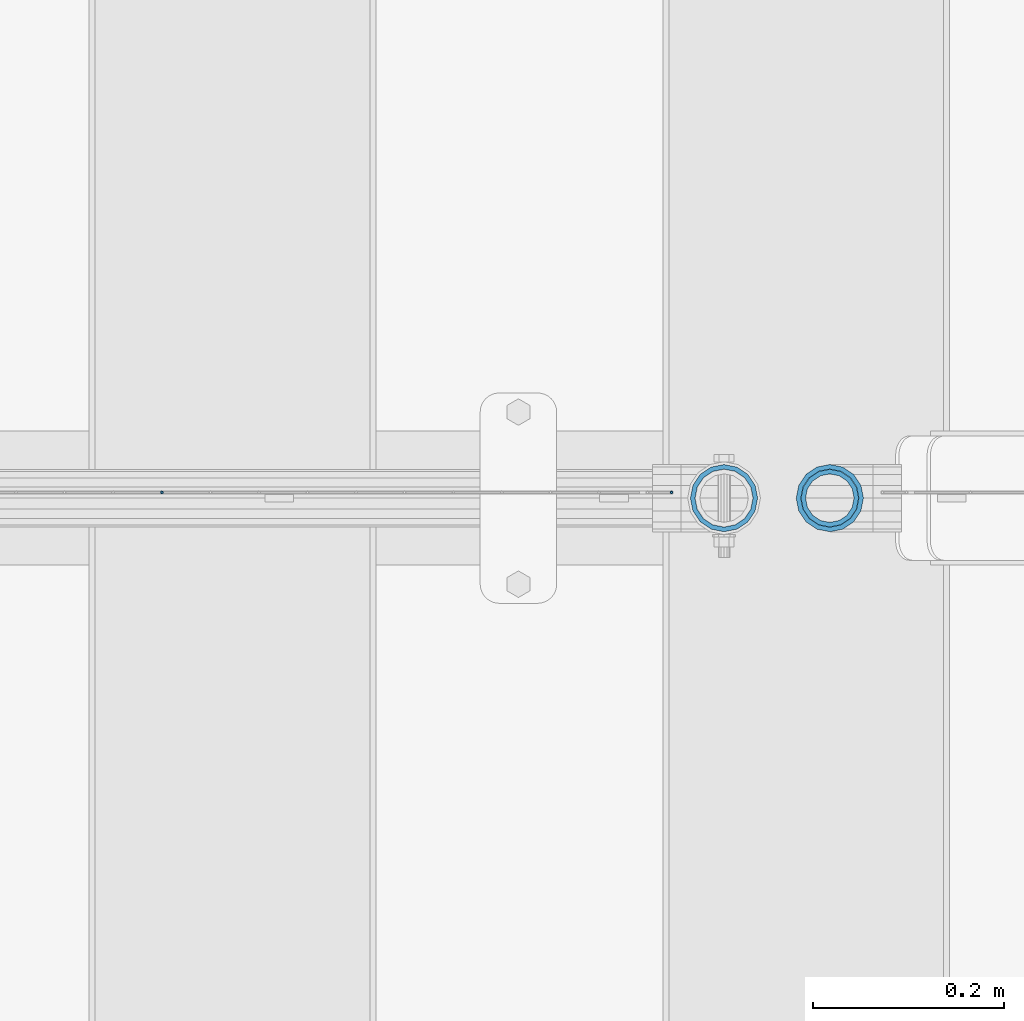
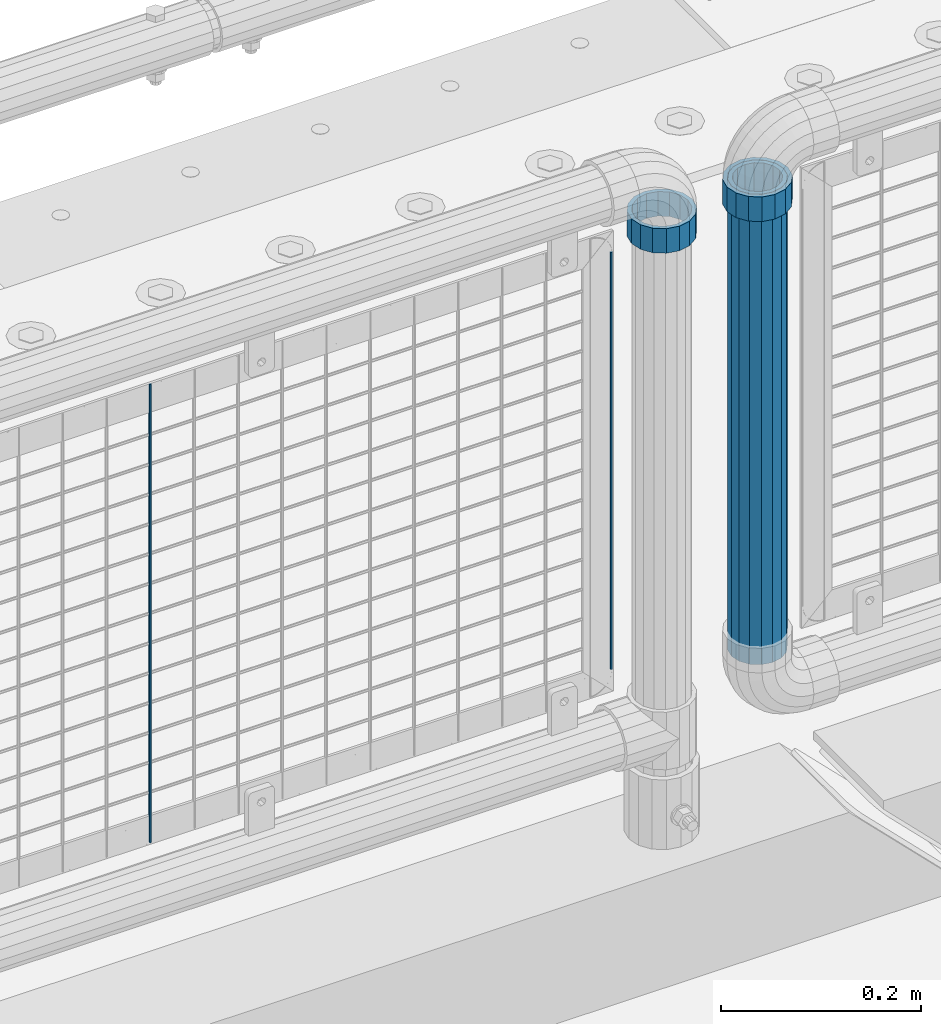
# One storey, part 109 of 270: 5 columns.
"""IFC2X3 building model written with IfcOpenShell, lengths in millimetres."""

import ifcopenshell
import ifcopenshell.guid

model = None  # the IFC model being written
_history = None  # IfcOwnerHistory: only IFC2X3 demands one
_inside = {}  # id of a spatial element -> (the spatial element, [elements in it])
_under = {}  # id of a project, library or spatial element -> (it, [spatial elements below it])
_declared = {}  # id of a project -> (the project, [libraries it declares])
_typed = {}  # id of a type object -> (the type object, [elements of that type])
_made_of = {}  # id of a material, layer set ... -> (it, [elements and type objects made of it])


def new_model(schema):
    """Start an empty IFC model of exactly this schema.

    Asked for "IFC4X3", IfcOpenShell would pick the latest addendum, in which some entities
    have other attributes; the version numbers below select the first issue.
    IFC2X3 requires an IfcOwnerHistory on every rooted entity: one is made here for all.
    """
    global model, _history
    if schema == "IFC4X3":
        model = ifcopenshell.file(schema_version=(4, 3, 0, 0))
    else:
        model = ifcopenshell.file(schema=schema)
    _inside.clear()
    _under.clear()
    _declared.clear()
    _typed.clear()
    _made_of.clear()
    _history = None
    if model.schema == "IFC2X3":
        org = make("IfcOrganization", Name="unknown")
        user = make(
            "IfcPersonAndOrganization",
            ThePerson=make("IfcPerson", FamilyName="unknown"),
            TheOrganization=org,
        )
        app = make(
            "IfcApplication",
            ApplicationDeveloper=org,
            Version="unknown",
            ApplicationFullName="unknown",
            ApplicationIdentifier="unknown",
        )
        _history = make(
            "IfcOwnerHistory",
            OwningUser=user,
            OwningApplication=app,
            ChangeAction="ADDED",
            CreationDate=0,
        )
    return model


def make(cls, **values):
    """One entity of the class cls with the attributes given. An attribute that is None is left unset."""
    return model.create_entity(
        cls, **{name: value for name, value in values.items() if value is not None}
    )


def rooted(cls, **values):
    """An entity with a GlobalId (a new one), such as an element, a storey or a relation."""
    return make(cls, GlobalId=ifcopenshell.guid.new(), OwnerHistory=_history, **values)


def si_unit(unit_type, name, prefix=None):
    """IfcSIUnit, for example si_unit("LENGTHUNIT", "METRE", prefix="MILLI")."""
    return make("IfcSIUnit", UnitType=unit_type, Prefix=prefix, Name=name)


def assignment(units):
    """IfcUnitAssignment: the units of a project."""
    return None if units is None else make("IfcUnitAssignment", Units=units)


def point(xyz):
    """IfcCartesianPoint."""
    return None if xyz is None else make("IfcCartesianPoint", Coordinates=xyz)


def direction(xyz):
    """IfcDirection."""
    return None if xyz is None else make("IfcDirection", DirectionRatios=xyz)


def frame(location, z_axis=None, x_axis=None):
    """IfcAxis2Placement3D, a coordinate frame: its origin and axes. An axis left out is left unset."""
    return make(
        "IfcAxis2Placement3D",
        Location=point(location),
        Axis=direction(z_axis),
        RefDirection=direction(x_axis),
    )


def origin_with_axes():
    """The frame at (0, 0, 0) with the z axis (0, 0, 1) and the x axis (1, 0, 0) written out."""
    return frame((0.0, 0.0, 0.0), z_axis=(0.0, 0.0, 1.0), x_axis=(1.0, 0.0, 0.0))


def place(relative_to, where):
    """IfcLocalPlacement: puts the frame where relative to a parent placement (None: the world)."""
    return make(
        "IfcLocalPlacement", PlacementRelTo=relative_to, RelativePlacement=where
    )


def context(
    kind, dimensions, precision=None, world=None, true_north=None, identifier=None
):
    """IfcGeometricRepresentationContext, for example the 3D "Model" context."""
    return make(
        "IfcGeometricRepresentationContext",
        ContextIdentifier=identifier,
        ContextType=kind,
        CoordinateSpaceDimension=dimensions,
        Precision=precision,
        WorldCoordinateSystem=world,
        TrueNorth=true_north,
    )


def subcontext(parent, identifier, kind, view, scale=None):
    """IfcGeometricRepresentationSubContext, for example "Body" below "Model"."""
    return make(
        "IfcGeometricRepresentationSubContext",
        ContextIdentifier=identifier,
        ContextType=kind,
        ParentContext=parent,
        TargetScale=scale,
        TargetView=view,
    )


def project(units=None, contexts=None):
    """IfcProject with its units and contexts."""
    return rooted(
        "IfcProject",
        Name="project",
        RepresentationContexts=contexts,
        UnitsInContext=assignment(units),
    )


def spatial(cls, under=None, at=None, **own):
    """A site, building, storey or space (cls), placed at a placement, below another one or the project."""
    s = rooted(cls, ObjectPlacement=at, **own)
    if under is not None:
        _under.setdefault(under.id(), (under, []))[1].append(s)
    return s


def faces_of(points, faces, orient=None, outer=None):
    """IfcFace entities. A face is a list of loops; a loop is a list of indices into points, from 0.

    orient and outer hold one flag for each loop. By default every Orientation is true, the
    first loop of a face is its IfcFaceOuterBound and the others are IfcFaceBound.
    """
    made = []
    for i, loops in enumerate(faces):
        bounds = []
        for j, loop in enumerate(loops):
            is_outer = j == 0 if outer is None else outer[i][j]
            bounds.append(
                make(
                    "IfcFaceOuterBound" if is_outer else "IfcFaceBound",
                    Bound=make("IfcPolyLoop", Polygon=[points[k] for k in loop]),
                    Orientation=True if orient is None else orient[i][j],
                )
            )
        made.append(make("IfcFace", Bounds=bounds))
    return made


def faceted_brep(points, faces, orient=None, outer=None, voids=None):
    """IfcFacetedBrep: a solid bounded by flat faces; with voids (closed shells), ...WithVoids."""
    shared = [point(p) for p in points]
    hull = make("IfcClosedShell", CfsFaces=faces_of(shared, faces, orient, outer))
    if voids is None:
        return make("IfcFacetedBrep", Outer=hull)
    return make(
        "IfcFacetedBrepWithVoids",
        Outer=hull,
        Voids=[
            make(cls, CfsFaces=faces_of(shared, fs, o, b)) for cls, fs, o, b in voids
        ],
    )


def shape(context_of_items, identifier, shape_type, items):
    """IfcShapeRepresentation: the items that make up one representation, for example the "Body"."""
    return make(
        "IfcShapeRepresentation",
        ContextOfItems=context_of_items,
        RepresentationIdentifier=identifier,
        RepresentationType=shape_type,
        Items=items,
    )


def material(Name=None, Category=None):
    """IfcMaterial."""
    return make("IfcMaterial", Name=Name, Category=Category)


def made_of(thing, what):
    """Note that an element or type object is made of a material, layer set ...; save() writes the relation."""
    if what is not None:
        _made_of.setdefault(what.id(), (what, []))[1].append(thing)
    return thing


def type_object(cls, material=None, **own):
    """A type object (cls), such as IfcWallType, which elements share."""
    return made_of(rooted(cls, **own), material)


def element(
    cls,
    number,
    at=None,
    inside=None,
    cuts=None,
    type_object=None,
    material=None,
    context=None,
    identifier="Body",
    shape_type=None,
    held_by="IfcProductDefinitionShape",
    body=None,
    shapes=None,
    **own,
):
    """One element of the class cls, such as IfcWall. Its Tag is "e" and its number.

    at: its placement. inside: the storey or other place that contains it. cuts: it is an
    opening in that element (IfcRelVoidsElement). A single representation is given by context,
    identifier, shape_type and body (its items); several are given by shapes. held_by: the class
    of the entity that holds the representations. save() writes the other relations.
    """
    e = rooted(cls, Tag="e%d" % number, ObjectPlacement=at, **own)
    if body is not None:
        shapes = [shape(context, identifier, shape_type, body)]
    if shapes is not None:
        e.Representation = make(held_by, Representations=shapes)
    if inside is not None:
        _inside.setdefault(inside.id(), (inside, []))[1].append(e)
    if cuts is not None:
        rooted(
            "IfcRelVoidsElement", RelatingBuildingElement=cuts, RelatedOpeningElement=e
        )
    if type_object is not None:
        _typed.setdefault(type_object.id(), (type_object, []))[1].append(e)
    return made_of(e, material)


def aggregate(whole, parts):
    """IfcRelAggregates: a whole, such as a stair, and the parts it consists of."""
    return rooted("IfcRelAggregates", RelatingObject=whole, RelatedObjects=parts)


def save(model, path):
    """Write the relations noted so far, then the file.

    IfcRelAggregates (storeys below a building ...), IfcRelContainedInSpatialStructure (elements
    in a storey), IfcRelDefinesByType, IfcRelAssociatesMaterial and IfcRelDeclares: one each for
    every whole, place, type object, material and project.
    """
    for whole, parts in _under.values():
        aggregate(whole, parts)
    for where, things in _inside.values():
        rooted(
            "IfcRelContainedInSpatialStructure",
            RelatedElements=things,
            RelatingStructure=where,
        )
    for kind, things in _typed.values():
        rooted("IfcRelDefinesByType", RelatedObjects=things, RelatingType=kind)
    for what, things in _made_of.values():
        rooted("IfcRelAssociatesMaterial", RelatedObjects=things, RelatingMaterial=what)
    for by, libraries in _declared.values():
        rooted("IfcRelDeclares", RelatingContext=by, RelatedDefinitions=libraries)
    model.write(path)


model = new_model("IFC2X3")

# Units and contexts
model_context = context("Model", 3, precision=1e-05, world=origin_with_axes())
body_context = subcontext(model_context, "Body", "Model", "MODEL_VIEW")
ifc_project = project(units=[si_unit("LENGTHUNIT", "METRE", prefix="MILLI"), si_unit("AREAUNIT", "SQUARE_METRE"), si_unit("VOLUMEUNIT", "CUBIC_METRE"), si_unit("MASSUNIT", "GRAM", prefix="KILO"), si_unit("TIMEUNIT", "SECOND"), si_unit("PLANEANGLEUNIT", "RADIAN"), si_unit("SOLIDANGLEUNIT", "STERADIAN"), si_unit("THERMODYNAMICTEMPERATUREUNIT", "DEGREE_CELSIUS"), si_unit("LUMINOUSINTENSITYUNIT", "LUMEN")], contexts=[model_context])

# Site, building, storey
site_placement = place(None, origin_with_axes())
site = spatial("IfcSite", under=ifc_project, at=site_placement, CompositionType="ELEMENT")
building_placement = place(site_placement, origin_with_axes())
building = spatial("IfcBuilding", under=site, at=building_placement, Name="Standard", CompositionType="ELEMENT")
storey_placement = place(building_placement, origin_with_axes())
storey = spatial("IfcBuildingStorey", under=building, at=storey_placement, Name="Undefined", CompositionType="ELEMENT", Elevation=0.0)

# Columns
ifc_material_1 = material()
column_type_1 = type_object("IfcColumnType", PredefinedType="NOTDEFINED")
column_1_placement = place(storey_placement, frame((18694.61, -16335.5, 349.86), z_axis=(-1.0, 0.0, 0.0), x_axis=(0.0, 0.0, 1.0)))
element("IfcColumn", 1, at=column_1_placement, inside=storey, type_object=column_type_1, material=ifc_material_1, context=body_context, shape_type="Brep", body=[
    faceted_brep([(0.0, -25.3500000000004, 0.0), (0.0, -23.4203461491616, 9.70102501045403), (574.992910334213, -23.4203461491616, 9.70102501045403), (574.990000024649, -25.3500000000004, 0.0), (0.0, -17.9251569030785, 17.9251569030785), (574.995377579387, -17.9251569030785, 17.9251569030785), (0.0, -9.70102501045585, 23.4203461491597), (574.997026144459, -9.70102501045585, 23.4203461491597), (0.0, 0.0, 25.3499999999985), (574.997605050341, 0.0, 25.3499999999985), (0.0, 9.70102501045585, 23.4203461491597), (574.997026163861, 9.70102501045585, 23.4203461491597), (0.0, 17.9251569030785, 17.9251569030785), (574.995377615237, 17.9251569030785, 17.9251569030785), (0.0, 23.4203461491616, 9.70102501045403), (574.992910381054, 23.4203461491616, 9.70102501045403), (0.0, 25.3500000000004, 0.0), (574.990000075349, 25.3500000000004, 0.0), (0.0, 23.4203461491616, -9.70102501045403), (574.987089765785, 23.4203461491616, -9.70102501045403), (0.0, 17.9251569030785, -17.9251569030785), (574.984622520612, 17.9251569030785, -17.9251569030785), (0.0, 9.70102501045585, -23.4203461491597), (574.982973955539, 9.70102501045585, -23.4203461491597), (0.0, 0.0, -25.3499999999985), (574.982395049657, 0.0, -25.3499999999985), (0.0, -9.70102501045585, -23.4203461491597), (574.982973936137, -9.70102501045585, -23.4203461491597), (0.0, -17.9251569030785, -17.9251569030785), (574.984622484761, -17.9251569030785, -17.9251569030785), (0.0, -23.4203461491616, -9.70102501045403), (574.987089718945, -23.4203461491616, -9.70102501045403), (0.0, -30.1499999999996, 0.0), (0.0, -27.8549679052157, -11.5379054858058), (574.986538650343, -27.8549679052157, -11.5379054858058), (574.990000019849, -30.1499999999996, 0.0), (0.0, -21.3192694527752, -21.3192694527752), (574.983604247556, -21.3192694527752, -21.3192694527752), (0.0, -11.5379054858076, -27.8549679052157), (574.981643547714, -11.5379054858076, -27.8549679052157), (0.0, 0.0, -30.1500000000015), (574.980955049592, 0.0, -30.1500000000015), (0.0, 11.5379054858076, -27.8549679052157), (574.98164357079, 11.5379054858076, -27.8549679052157), (0.0, 21.3192694527752, -21.3192694527752), (574.983604290195, 21.3192694527752, -21.3192694527752), (0.0, 27.8549679052157, -11.5379054858058), (574.986538706053, 27.8549679052157, -11.5379054858058), (0.0, 30.1499999999996, 0.0), (574.990000080149, 30.1499999999996, 0.0), (0.0, 27.8549679052157, 11.5379054858058), (574.993461449656, 27.8549679052157, 11.5379054858058), (0.0, 21.3192694527752, 21.3192694527752), (574.996395852442, 21.3192694527752, 21.3192694527752), (0.0, 11.5379054858076, 27.8549679052157), (574.998356552285, 11.5379054858076, 27.8549679052157), (0.0, 0.0, 30.1500000000015), (574.999045050406, 0.0, 30.1500000000015), (0.0, -11.5379054858076, 27.8549679052157), (574.998356529209, -11.5379054858076, 27.8549679052157), (0.0, -21.3192694527752, 21.3192694527752), (574.996395809804, -21.3192694527752, 21.3192694527752), (0.0, -27.8549679052157, 11.5379054858058), (574.993461393946, -27.8549679052157, 11.5379054858058)], [[[0, 1, 2, 3]], [[1, 4, 5, 2]], [[4, 6, 7, 5]], [[6, 8, 9, 7]], [[8, 10, 11, 9]], [[10, 12, 13, 11]], [[12, 14, 15, 13]], [[14, 16, 17, 15]], [[16, 18, 19, 17]], [[18, 20, 21, 19]], [[20, 22, 23, 21]], [[22, 24, 25, 23]], [[24, 26, 27, 25]], [[26, 28, 29, 27]], [[28, 30, 31, 29]], [[30, 0, 3, 31]], [[32, 33, 34, 35]], [[33, 36, 37, 34]], [[36, 38, 39, 37]], [[38, 40, 41, 39]], [[40, 42, 43, 41]], [[42, 44, 45, 43]], [[44, 46, 47, 45]], [[46, 48, 49, 47]], [[48, 50, 51, 49]], [[50, 52, 53, 51]], [[52, 54, 55, 53]], [[54, 56, 57, 55]], [[56, 58, 59, 57]], [[58, 60, 61, 59]], [[60, 62, 63, 61]], [[62, 32, 35, 63]], [[37, 39, 41, 43, 45, 47, 49, 51, 53, 55, 57, 59, 61, 63, 35, 34], [5, 7, 9, 11, 13, 15, 17, 19, 21, 23, 25, 27, 29, 31, 3, 2]], [[62, 60, 58, 56, 54, 52, 50, 48, 46, 44, 42, 40, 38, 36, 33, 32], [30, 28, 26, 24, 22, 20, 18, 16, 14, 12, 10, 8, 6, 4, 1, 0]]]),
])
ifc_material_2 = material(Name="Misc_Undefined")
column_type_2 = type_object("IfcColumnType", PredefinedType="NOTDEFINED")
column_2_placement = place(storey_placement, frame((18584.0, -16335.5, 894.85), z_axis=(1.0, 0.0, 0.0), x_axis=(0.0, 0.0, 1.0)))
element("IfcColumn", 2, at=column_2_placement, inside=storey, type_object=column_type_2, material=ifc_material_2, context=body_context, shape_type="Brep", body=[
    faceted_brep([(0.0, -30.3500000000004, 0.0), (0.0, -28.0397438117179, 11.614442172282), (30.0, -28.0397438117179, 11.6144421722805), (30.0, -30.3500000000004, 0.0), (0.0, -21.4606908090118, 21.46069080901), (30.0, -21.4606908090118, 21.4606908090117), (0.0, -11.6144421722802, 28.0397438117179), (30.0, -11.6144421722802, 28.0397438117176), (0.0, 0.0, 30.3499999999985), (30.0, 0.0, 30.35), (0.0, 11.6144421722802, 28.0397438117179), (30.0, 11.6144421722802, 28.0397438117176), (0.0, 21.4606908090118, 21.46069080901), (30.0, 21.4606908090118, 21.4606908090117), (0.0, 28.0397438117179, 11.614442172282), (30.0, 28.0397438117179, 11.6144421722805), (0.0, 30.3500000000004, 0.0), (30.0, 30.3500000000004, 0.0), (0.0, 28.0397438117179, -11.614442172282), (30.0, 28.0397438117179, -11.6144421722805), (0.0, 21.4606908090118, -21.46069080901), (30.0, 21.4606908090118, -21.4606908090117), (0.0, 11.6144421722802, -28.0397438117179), (30.0, 11.6144421722802, -28.0397438117176), (0.0, 0.0, -30.3499999999985), (30.0, 0.0, -30.35), (0.0, -11.6144421722802, -28.0397438117179), (30.0, -11.6144421722802, -28.0397438117176), (0.0, -21.4606908090118, -21.46069080901), (30.0, -21.4606908090118, -21.4606908090117), (0.0, -28.0397438117179, -11.614442172282), (30.0, -28.0397438117179, -11.6144421722805), (0.0, -35.1499999999996, 0.0), (0.0, -32.4743655677721, -13.4513226476338), (30.0, -32.4743655677721, -13.4513226476329), (30.0, -35.1499999999996, 0.0), (0.0, -24.8548033587067, -24.8548033587067), (30.0, -24.8548033587067, -24.8548033587072), (0.0, -13.4513226476338, -32.4743655677703), (30.0, -13.4513226476338, -32.4743655677718), (0.0, 0.0, -35.1499999999996), (30.0, 0.0, -35.15), (0.0, 13.4513226476338, -32.4743655677703), (30.0, 13.4513226476338, -32.4743655677718), (0.0, 24.8548033587067, -24.8548033587067), (30.0, 24.8548033587067, -24.8548033587072), (0.0, 32.4743655677721, -13.4513226476338), (30.0, 32.4743655677721, -13.4513226476329), (0.0, 35.1499999999996, 0.0), (30.0, 35.1499999999996, 0.0), (0.0, 32.4743655677721, 13.4513226476338), (30.0, 32.4743655677721, 13.4513226476329), (0.0, 24.8548033587067, 24.8548033587067), (30.0, 24.8548033587067, 24.8548033587072), (0.0, 13.4513226476338, 32.4743655677703), (30.0, 13.4513226476338, 32.4743655677718), (0.0, 0.0, 35.1499999999996), (30.0, 0.0, 35.15), (0.0, -13.4513226476338, 32.4743655677703), (30.0, -13.4513226476338, 32.4743655677718), (0.0, -24.8548033587067, 24.8548033587067), (30.0, -24.8548033587067, 24.8548033587072), (0.0, -32.4743655677721, 13.4513226476338), (30.0, -32.4743655677721, 13.4513226476329)], [[[0, 1, 2, 3]], [[1, 4, 5, 2]], [[4, 6, 7, 5]], [[6, 8, 9, 7]], [[8, 10, 11, 9]], [[10, 12, 13, 11]], [[12, 14, 15, 13]], [[14, 16, 17, 15]], [[16, 18, 19, 17]], [[18, 20, 21, 19]], [[20, 22, 23, 21]], [[22, 24, 25, 23]], [[24, 26, 27, 25]], [[26, 28, 29, 27]], [[28, 30, 31, 29]], [[30, 0, 3, 31]], [[32, 33, 34, 35]], [[33, 36, 37, 34]], [[36, 38, 39, 37]], [[38, 40, 41, 39]], [[40, 42, 43, 41]], [[42, 44, 45, 43]], [[44, 46, 47, 45]], [[46, 48, 49, 47]], [[48, 50, 51, 49]], [[50, 52, 53, 51]], [[52, 54, 55, 53]], [[54, 56, 57, 55]], [[56, 58, 59, 57]], [[58, 60, 61, 59]], [[60, 62, 63, 61]], [[62, 32, 35, 63]], [[37, 39, 41, 43, 45, 47, 49, 51, 53, 55, 57, 59, 61, 63, 35, 34], [5, 7, 9, 11, 13, 15, 17, 19, 21, 23, 25, 27, 29, 31, 3, 2]], [[62, 60, 58, 56, 54, 52, 50, 48, 46, 44, 42, 40, 38, 36, 33, 32], [30, 28, 26, 24, 22, 20, 18, 16, 14, 12, 10, 8, 6, 4, 1, 0]]]),
])
column_3_placement = place(storey_placement, frame((18694.61, -16335.5, 894.849999999999), z_axis=(-1.0, 0.0, 0.0), x_axis=(0.0, 0.0, 1.0)))
element("IfcColumn", 3, at=column_3_placement, inside=storey, type_object=column_type_2, material=ifc_material_2, context=body_context, shape_type="Brep", body=[
    faceted_brep([(0.0, -30.3500000000004, 0.0), (0.0, -28.0397438117179, 11.614442172282), (30.0, -28.0397438117179, 11.6144421722805), (30.0, -30.3500000000004, 0.0), (0.0, -21.4606908090118, 21.46069080901), (30.0, -21.4606908090118, 21.4606908090117), (0.0, -11.6144421722802, 28.0397438117179), (30.0, -11.6144421722802, 28.0397438117176), (0.0, 0.0, 30.3499999999985), (30.0, 0.0, 30.35), (0.0, 11.6144421722802, 28.0397438117179), (30.0, 11.6144421722802, 28.0397438117176), (0.0, 21.4606908090118, 21.46069080901), (30.0, 21.4606908090118, 21.4606908090117), (0.0, 28.0397438117179, 11.614442172282), (30.0, 28.0397438117179, 11.6144421722805), (0.0, 30.3500000000004, 0.0), (30.0, 30.3500000000004, 0.0), (0.0, 28.0397438117179, -11.614442172282), (30.0, 28.0397438117179, -11.6144421722805), (0.0, 21.4606908090118, -21.46069080901), (30.0, 21.4606908090118, -21.4606908090117), (0.0, 11.6144421722802, -28.0397438117179), (30.0, 11.6144421722802, -28.0397438117176), (0.0, 0.0, -30.3499999999985), (30.0, 0.0, -30.35), (0.0, -11.6144421722802, -28.0397438117179), (30.0, -11.6144421722802, -28.0397438117176), (0.0, -21.4606908090118, -21.46069080901), (30.0, -21.4606908090118, -21.4606908090117), (0.0, -28.0397438117179, -11.614442172282), (30.0, -28.0397438117179, -11.6144421722805), (0.0, -35.1499999999996, 0.0), (0.0, -32.4743655677721, -13.4513226476338), (30.0, -32.4743655677721, -13.4513226476329), (30.0, -35.1499999999996, 0.0), (0.0, -24.8548033587067, -24.8548033587067), (30.0, -24.8548033587067, -24.8548033587072), (0.0, -13.4513226476338, -32.4743655677703), (30.0, -13.4513226476338, -32.4743655677718), (0.0, 0.0, -35.1499999999996), (30.0, 0.0, -35.15), (0.0, 13.4513226476338, -32.4743655677703), (30.0, 13.4513226476338, -32.4743655677718), (0.0, 24.8548033587067, -24.8548033587067), (30.0, 24.8548033587067, -24.8548033587072), (0.0, 32.4743655677721, -13.4513226476338), (30.0, 32.4743655677721, -13.4513226476329), (0.0, 35.1499999999996, 0.0), (30.0, 35.1499999999996, 0.0), (0.0, 32.4743655677721, 13.4513226476338), (30.0, 32.4743655677721, 13.4513226476329), (0.0, 24.8548033587067, 24.8548033587067), (30.0, 24.8548033587067, 24.8548033587072), (0.0, 13.4513226476338, 32.4743655677703), (30.0, 13.4513226476338, 32.4743655677718), (0.0, 0.0, 35.1499999999996), (30.0, 0.0, 35.15), (0.0, -13.4513226476338, 32.4743655677703), (30.0, -13.4513226476338, 32.4743655677718), (0.0, -24.8548033587067, 24.8548033587067), (30.0, -24.8548033587067, 24.8548033587072), (0.0, -32.4743655677721, 13.4513226476338), (30.0, -32.4743655677721, 13.4513226476329)], [[[0, 1, 2, 3]], [[1, 4, 5, 2]], [[4, 6, 7, 5]], [[6, 8, 9, 7]], [[8, 10, 11, 9]], [[10, 12, 13, 11]], [[12, 14, 15, 13]], [[14, 16, 17, 15]], [[16, 18, 19, 17]], [[18, 20, 21, 19]], [[20, 22, 23, 21]], [[22, 24, 25, 23]], [[24, 26, 27, 25]], [[26, 28, 29, 27]], [[28, 30, 31, 29]], [[30, 0, 3, 31]], [[32, 33, 34, 35]], [[33, 36, 37, 34]], [[36, 38, 39, 37]], [[38, 40, 41, 39]], [[40, 42, 43, 41]], [[42, 44, 45, 43]], [[44, 46, 47, 45]], [[46, 48, 49, 47]], [[48, 50, 51, 49]], [[50, 52, 53, 51]], [[52, 54, 55, 53]], [[54, 56, 57, 55]], [[56, 58, 59, 57]], [[58, 60, 61, 59]], [[60, 62, 63, 61]], [[62, 32, 35, 63]], [[37, 39, 41, 43, 45, 47, 49, 51, 53, 55, 57, 59, 61, 63, 35, 34], [5, 7, 9, 11, 13, 15, 17, 19, 21, 23, 25, 27, 29, 31, 3, 2]], [[62, 60, 58, 56, 54, 52, 50, 48, 46, 44, 42, 40, 38, 36, 33, 32], [30, 28, 26, 24, 22, 20, 18, 16, 14, 12, 10, 8, 6, 4, 1, 0]]]),
])
column_type_3 = type_object("IfcColumnType", Name="D3", PredefinedType="NOTDEFINED")
column_4_placement = place(storey_placement, frame((17996.067, -16329.5, 353.02), z_axis=(-1.0, 0.0, 0.0), x_axis=(0.0, 0.0, 1.0)))
element("IfcColumn", 4, at=column_4_placement, inside=storey, type_object=column_type_3, material=ifc_material_2, ObjectType="D3", context=body_context, shape_type="Brep", body=[
    faceted_brep([(0.0, -1.5, 0.0), (0.0, -0.75, -1.29903810567669), (560.0, -0.75, -1.29903810567703), (560.0, -1.5, 0.0), (0.0, 0.75, -1.29903810567669), (560.0, 0.75, -1.29903810567703), (0.0, 1.5, 0.0), (560.0, 1.5, 0.0), (0.0, 0.75, 1.29903810567669), (560.0, 0.75, 1.29903810567703), (0.0, -0.75, 1.29903810567669), (560.0, -0.75, 1.29903810567703)], [[[0, 1, 2, 3]], [[1, 4, 5, 2]], [[4, 6, 7, 5]], [[6, 8, 9, 7]], [[8, 10, 11, 9]], [[10, 0, 3, 11]], [[5, 7, 9, 11, 3, 2]], [[10, 8, 6, 4, 1, 0]]]),
])
column_5_placement = place(storey_placement, frame((18529.0, -16329.5, 378.02), z_axis=(-1.0, 0.0, 0.0), x_axis=(0.0, 0.0, 1.0)))
element("IfcColumn", 5, at=column_5_placement, inside=storey, type_object=column_type_3, material=ifc_material_2, ObjectType="D3", context=body_context, shape_type="Brep", body=[
    faceted_brep([(0.0, -1.5, 0.0), (0.0, -0.75, -1.29903810567669), (510.0, -0.75, -1.29903810567703), (510.0, -1.5, 0.0), (0.0, 0.75, -1.29903810567669), (510.0, 0.75, -1.29903810567703), (0.0, 1.5, 0.0), (510.0, 1.5, 0.0), (0.0, 0.75, 1.29903810567669), (510.0, 0.75, 1.29903810567703), (0.0, -0.75, 1.29903810567669), (510.0, -0.75, 1.29903810567703)], [[[0, 1, 2, 3]], [[1, 4, 5, 2]], [[4, 6, 7, 5]], [[6, 8, 9, 7]], [[8, 10, 11, 9]], [[10, 0, 3, 11]], [[5, 7, 9, 11, 3, 2]], [[10, 8, 6, 4, 1, 0]]]),
])

save(model, "model.ifc")
